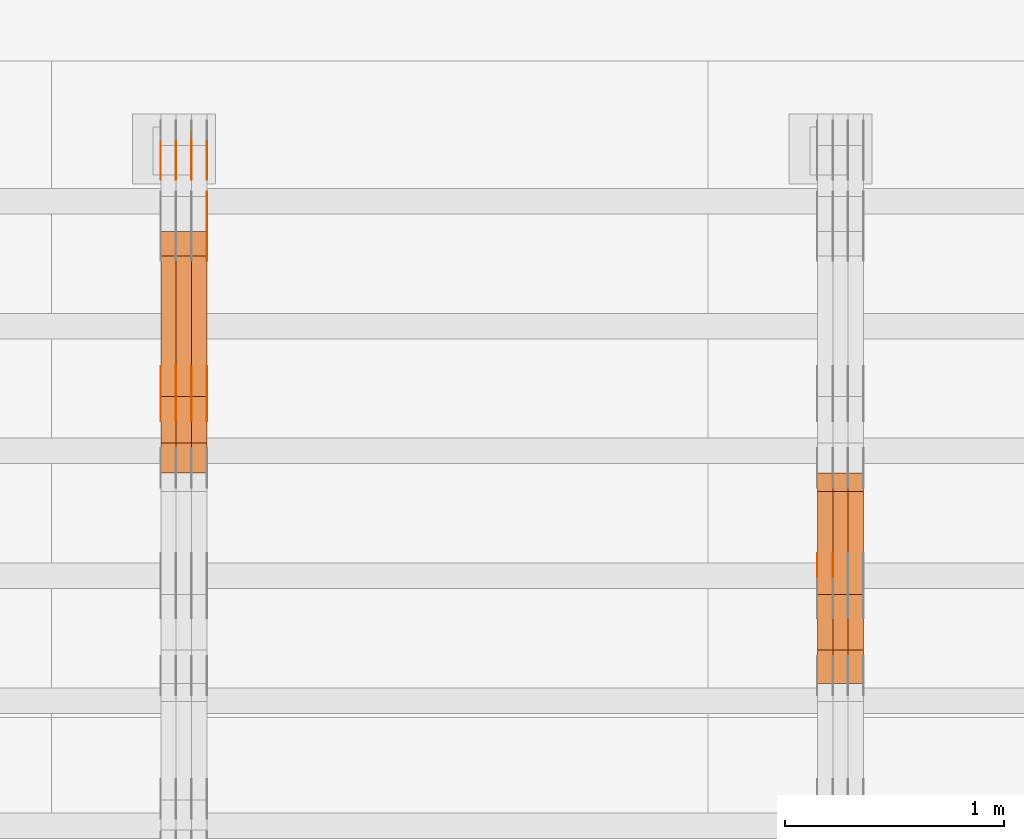
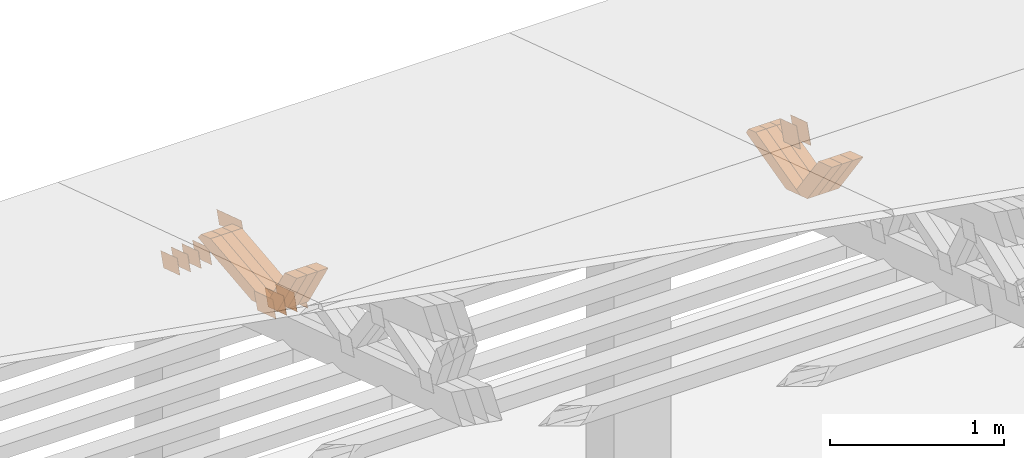
# One storey, part 348 of 385: 28 proxies.
"""IFC2X3 building model written with IfcOpenShell, lengths in millimetres."""

from ifc_helpers import new_model, entity, si_unit, converted_unit, derived_unit, direction, frame, origin, place, context, subcontext, project, spatial, polyline, outline, extrude, source, transform, mapped, material, type_object, type_shapes, element, save


model = new_model("IFC2X3")

# Units and contexts
model_context = context("Model", 3, precision=0.01, world=origin(), true_north=direction((6.12303176911189e-17, 1.0)))
body_context = subcontext(model_context, "Body", "Model", "MODEL_VIEW")
ifc_project = project(units=[si_unit("LENGTHUNIT", "METRE", prefix="MILLI"), si_unit("AREAUNIT", "SQUARE_METRE"), si_unit("VOLUMEUNIT", "CUBIC_METRE"), converted_unit("PLANEANGLEUNIT", "DEGREE", entity("IfcRatioMeasure", 0.0174532925199433), si_unit("PLANEANGLEUNIT", "RADIAN"), dimensions=[0, 0, 0, 0, 0, 0, 0]), si_unit("MASSUNIT", "GRAM", prefix="KILO"), derived_unit("MASSDENSITYUNIT", [(si_unit("MASSUNIT", "GRAM", prefix="KILO"), 1), (si_unit("LENGTHUNIT", "METRE"), -3)]), si_unit("TIMEUNIT", "SECOND"), si_unit("FREQUENCYUNIT", "HERTZ"), si_unit("THERMODYNAMICTEMPERATUREUNIT", "DEGREE_CELSIUS"), derived_unit("THERMALTRANSMITTANCEUNIT", [(si_unit("MASSUNIT", "GRAM", prefix="KILO"), 1), (si_unit("THERMODYNAMICTEMPERATUREUNIT", "KELVIN"), -1), (si_unit("TIMEUNIT", "SECOND"), -3)]), derived_unit("VOLUMETRICFLOWRATEUNIT", [(si_unit("LENGTHUNIT", "METRE"), 3), (si_unit("TIMEUNIT", "SECOND"), -1)]), si_unit("ELECTRICCURRENTUNIT", "AMPERE"), si_unit("ELECTRICVOLTAGEUNIT", "VOLT"), si_unit("POWERUNIT", "WATT"), si_unit("FORCEUNIT", "NEWTON", prefix="KILO"), si_unit("ILLUMINANCEUNIT", "LUX"), si_unit("LUMINOUSFLUXUNIT", "LUMEN"), si_unit("LUMINOUSINTENSITYUNIT", "CANDELA"), derived_unit("USERDEFINED", [(si_unit("MASSUNIT", "GRAM", prefix="KILO"), -1), (si_unit("LENGTHUNIT", "METRE"), -2), (si_unit("TIMEUNIT", "SECOND"), 3), (si_unit("LUMINOUSFLUXUNIT", "LUMEN"), 1)]), derived_unit("LINEARVELOCITYUNIT", [(si_unit("LENGTHUNIT", "METRE"), 1), (si_unit("TIMEUNIT", "SECOND"), -1)]), si_unit("PRESSUREUNIT", "PASCAL"), derived_unit("USERDEFINED", [(si_unit("LENGTHUNIT", "METRE"), -2), (si_unit("MASSUNIT", "GRAM", prefix="KILO"), 1), (si_unit("TIMEUNIT", "SECOND"), -2)])], contexts=[model_context])

# Site, building, storey
site_placement = place(None, origin())
site = spatial("IfcSite", under=ifc_project, at=site_placement, CompositionType="ELEMENT")
building_placement = place(site_placement, origin())
building = spatial("IfcBuilding", under=site, at=building_placement, CompositionType="ELEMENT")
storey_placement = place(building_placement, origin())
storey = spatial("IfcBuildingStorey", under=building, at=storey_placement, Name="Default", CompositionType="ELEMENT", Elevation=0.0)

# Proxies
ifc_material_1 = material(Name="IfcSurfaceStyle #467325")
building_element_proxy_type_1 = type_object("IfcBuildingElementProxyType", PredefinedType="NOTDEFINED", material=ifc_material_1)
shared_shape_1 = source(origin(), body_context, "Body", "SweptSolid", [
    extrude(outline(polyline([(-100.000009625089, -72.0000630699202), (100.000090167682, -72.0000630699202), (100.000009625089, 72.0000630699202), (-100.000090167682, 72.0000630699202), (-100.000009625089, -72.0000630699202)])), frame((100.000090167682, 72.0000630699202, 0.0), z_axis=(0.0, 0.0, 1.0), x_axis=(-1.0, 0.0, 0.0)), (0.0, 0.0, 1.0), 1.29999999999998),
])
type_shapes(building_element_proxy_type_1, [shared_shape_1])
proxy_1_placement = place(building_placement, frame((39245.0, 24447.7695802369, 1088.58717039832), z_axis=(-1.0, 0.0, 0.0), x_axis=(0.0, -0.951056516295154, 0.309016994374948)))
element("IfcBuildingElementProxy", 1, at=proxy_1_placement, inside=storey, type_object=building_element_proxy_type_1, material=ifc_material_1, context=body_context, shape_type="MappedRepresentation", body=[
    mapped(shared_shape_1, transform((0.0, 0.0, 0.0), scale=1.0)),
])
ifc_material_2 = material(Name="IfcSurfaceStyle #467268")
building_element_proxy_type_2 = type_object("IfcBuildingElementProxyType", PredefinedType="NOTDEFINED", material=ifc_material_2)
shared_shape_2 = source(origin(), body_context, "Body", "SweptSolid", [
    extrude(outline(polyline([(-100.000009625089, -72.0000630699202), (100.000090167682, -72.0000630699202), (100.000009625089, 72.0000630699202), (-100.000090167682, 72.0000630699202), (-100.000009625089, -72.0000630699202)])), frame((100.000090167682, 72.0000630699202, 0.0), z_axis=(0.0, 0.0, 1.0), x_axis=(-1.0, 0.0, 0.0)), (0.0, 0.0, 1.0), 1.29999999999998),
])
type_shapes(building_element_proxy_type_2, [shared_shape_2])
proxy_2_placement = place(building_placement, frame((39246.3, 24447.7695802369, 1088.58717039832), z_axis=(-1.0, 0.0, 0.0), x_axis=(0.0, -0.951056516295154, 0.309016994374948)))
element("IfcBuildingElementProxy", 2, at=proxy_2_placement, inside=storey, type_object=building_element_proxy_type_2, material=ifc_material_2, context=body_context, shape_type="MappedRepresentation", body=[
    mapped(shared_shape_2, transform((0.0, 0.0, 0.0), scale=1.0)),
])
ifc_material_3 = material(Name="IfcSurfaceStyle #467211")
building_element_proxy_type_3 = type_object("IfcBuildingElementProxyType", PredefinedType="NOTDEFINED", material=ifc_material_3)
shared_shape_3 = source(origin(), body_context, "Body", "SweptSolid", [
    extrude(outline(polyline([(-100.000009625089, -72.0000630699202), (100.000090167682, -72.0000630699202), (100.000009625089, 72.0000630699202), (-100.000090167682, 72.0000630699202), (-100.000009625089, -72.0000630699202)])), frame((100.000090167682, 72.0000630699202, 0.0), z_axis=(0.0, 0.0, 1.0), x_axis=(-1.0, 0.0, 0.0)), (0.0, 0.0, 1.0), 1.29999999999999),
])
type_shapes(building_element_proxy_type_3, [shared_shape_3])
proxy_3_placement = place(building_placement, frame((39175.0, 24447.7695802369, 1088.58717039832), z_axis=(-1.0, 0.0, 0.0), x_axis=(0.0, -0.951056516295154, 0.309016994374948)))
element("IfcBuildingElementProxy", 3, at=proxy_3_placement, inside=storey, type_object=building_element_proxy_type_3, material=ifc_material_3, context=body_context, shape_type="MappedRepresentation", body=[
    mapped(shared_shape_3, transform((0.0, 0.0, 0.0), scale=1.0)),
])
ifc_material_4 = material(Name="IfcSurfaceStyle #458298")
building_element_proxy_type_4 = type_object("IfcBuildingElementProxyType", Name="T1-W24 458296", PredefinedType="NOTDEFINED", material=ifc_material_4)
shared_shape_4 = source(origin(), body_context, "Body", "SweptSolid", [
    extrude(outline(polyline([(-215.642157779899, -47.4998772343114), (220.829928576248, -47.4998772343114), (202.182343865616, 6.34871490324596e-05), (137.545638852774, 47.4998454907369), (-344.915753514738, 47.4998454907369), (-215.642157779899, -47.4998772343114)])), frame((220.830079609702, 47.500154567531, 0.0), z_axis=(0.0, 0.0, 1.0), x_axis=(-1.0, 0.0, 0.0)), (0.0, 0.0, 1.0), 70.0),
])
type_shapes(building_element_proxy_type_4, [shared_shape_4])
proxy_4_placement = place(building_placement, frame((39385.0, 24227.7045444998, 781.019082122604), z_axis=(-1.0, 0.0, 0.0), x_axis=(0.0, -0.583381854128324, 0.812198012970851)))
element("IfcBuildingElementProxy", 4, at=proxy_4_placement, inside=storey, type_object=building_element_proxy_type_4, material=ifc_material_4, Name="T1-W24", context=body_context, shape_type="MappedRepresentation", body=[
    mapped(shared_shape_4, transform((0.0, 0.0, 0.0), scale=1.0)),
])
ifc_material_5 = material(Name="IfcSurfaceStyle #458232")
building_element_proxy_type_5 = type_object("IfcBuildingElementProxyType", Name="T1-W24 458230", PredefinedType="NOTDEFINED", material=ifc_material_5)
shared_shape_5 = source(origin(), body_context, "Body", "SweptSolid", [
    extrude(outline(polyline([(-215.642157779899, -47.4998772343114), (220.829928576248, -47.4998772343114), (202.182343865616, 6.34871490324596e-05), (137.545638852774, 47.4998454907369), (-344.915753514738, 47.4998454907369), (-215.642157779899, -47.4998772343114)])), frame((220.830079609702, 47.500154567531, 0.0), z_axis=(0.0, 0.0, 1.0), x_axis=(-1.0, 0.0, 0.0)), (0.0, 0.0, 1.0), 70.0),
])
type_shapes(building_element_proxy_type_5, [shared_shape_5])
proxy_5_placement = place(building_placement, frame((39315.0, 24227.7045444998, 781.019082122604), z_axis=(-1.0, 0.0, 0.0), x_axis=(0.0, -0.583381854128324, 0.812198012970851)))
element("IfcBuildingElementProxy", 5, at=proxy_5_placement, inside=storey, type_object=building_element_proxy_type_5, material=ifc_material_5, Name="T1-W24", context=body_context, shape_type="MappedRepresentation", body=[
    mapped(shared_shape_5, transform((0.0, 0.0, 0.0), scale=1.0)),
])
ifc_material_6 = material(Name="IfcSurfaceStyle #458166")
building_element_proxy_type_6 = type_object("IfcBuildingElementProxyType", Name="T1-W24 458164", PredefinedType="NOTDEFINED", material=ifc_material_6)
shared_shape_6 = source(origin(), body_context, "Body", "SweptSolid", [
    extrude(outline(polyline([(-215.642157779899, -47.4998772343114), (220.829928576248, -47.4998772343114), (202.182343865616, 6.34871490324596e-05), (137.545638852774, 47.4998454907369), (-344.915753514738, 47.4998454907369), (-215.642157779899, -47.4998772343114)])), frame((220.830079609702, 47.500154567531, 0.0), z_axis=(0.0, 0.0, 1.0), x_axis=(-1.0, 0.0, 0.0)), (0.0, 0.0, 1.0), 70.0),
])
type_shapes(building_element_proxy_type_6, [shared_shape_6])
proxy_6_placement = place(building_placement, frame((39245.0, 24227.7045444998, 781.019082122604), z_axis=(-1.0, 0.0, 0.0), x_axis=(0.0, -0.583381854128324, 0.812198012970851)))
element("IfcBuildingElementProxy", 6, at=proxy_6_placement, inside=storey, type_object=building_element_proxy_type_6, material=ifc_material_6, Name="T1-W24", context=body_context, shape_type="MappedRepresentation", body=[
    mapped(shared_shape_6, transform((0.0, 0.0, 0.0), scale=1.0)),
])
ifc_material_7 = material(Name="IfcSurfaceStyle #457902")
building_element_proxy_type_7 = type_object("IfcBuildingElementProxyType", Name="T1-W13 457900", PredefinedType="NOTDEFINED", material=ifc_material_7)
shared_shape_7 = source(origin(), body_context, "Body", "SweptSolid", [
    extrude(outline(polyline([(-384.339592151497, -47.5000055308246), (150.996422207105, -47.5000055308247), (226.265349299398, -4.29484466835994e-05), (240.878612116891, 47.500027005048), (-233.800791471897, 47.500027005048), (-384.339592151497, -47.5000055308246)])), frame((240.878612116891, 47.500027005048, 0.0), z_axis=(0.0, 0.0, 1.0), x_axis=(-1.0, 0.0, 0.0)), (0.0, 0.0, 1.0), 70.0),
])
type_shapes(building_element_proxy_type_7, [shared_shape_7])
proxy_7_placement = place(building_placement, frame((39385.0, 24884.765625, 885.749145507813), z_axis=(-1.0, 0.0, 0.0), x_axis=(0.0, -0.969210894563555, -0.246232089418326)))
element("IfcBuildingElementProxy", 7, at=proxy_7_placement, inside=storey, type_object=building_element_proxy_type_7, material=ifc_material_7, Name="T1-W13", context=body_context, shape_type="MappedRepresentation", body=[
    mapped(shared_shape_7, transform((0.0, 0.0, 0.0), scale=1.0)),
])
ifc_material_8 = material(Name="IfcSurfaceStyle #457836")
building_element_proxy_type_8 = type_object("IfcBuildingElementProxyType", Name="T1-W13 457834", PredefinedType="NOTDEFINED", material=ifc_material_8)
shared_shape_8 = source(origin(), body_context, "Body", "SweptSolid", [
    extrude(outline(polyline([(-384.339592151497, -47.5000055308246), (150.996422207105, -47.5000055308247), (226.265349299398, -4.29484466835994e-05), (240.878612116891, 47.500027005048), (-233.800791471897, 47.500027005048), (-384.339592151497, -47.5000055308246)])), frame((240.878612116891, 47.500027005048, 0.0), z_axis=(0.0, 0.0, 1.0), x_axis=(-1.0, 0.0, 0.0)), (0.0, 0.0, 1.0), 70.0),
])
type_shapes(building_element_proxy_type_8, [shared_shape_8])
proxy_8_placement = place(building_placement, frame((39315.0, 24884.765625, 885.749145507813), z_axis=(-1.0, 0.0, 0.0), x_axis=(0.0, -0.969210894563555, -0.246232089418326)))
element("IfcBuildingElementProxy", 8, at=proxy_8_placement, inside=storey, type_object=building_element_proxy_type_8, material=ifc_material_8, Name="T1-W13", context=body_context, shape_type="MappedRepresentation", body=[
    mapped(shared_shape_8, transform((0.0, 0.0, 0.0), scale=1.0)),
])
ifc_material_9 = material(Name="IfcSurfaceStyle #457770")
building_element_proxy_type_9 = type_object("IfcBuildingElementProxyType", Name="T1-W13 457768", PredefinedType="NOTDEFINED", material=ifc_material_9)
shared_shape_9 = source(origin(), body_context, "Body", "SweptSolid", [
    extrude(outline(polyline([(-384.339592151497, -47.5000055308246), (150.996422207105, -47.5000055308247), (226.265349299398, -4.29484466835994e-05), (240.878612116891, 47.500027005048), (-233.800791471897, 47.500027005048), (-384.339592151497, -47.5000055308246)])), frame((240.878612116891, 47.500027005048, 0.0), z_axis=(0.0, 0.0, 1.0), x_axis=(-1.0, 0.0, 0.0)), (0.0, 0.0, 1.0), 70.0),
])
type_shapes(building_element_proxy_type_9, [shared_shape_9])
proxy_9_placement = place(building_placement, frame((39245.0, 24884.765625, 885.749145507813), z_axis=(-1.0, 0.0, 0.0), x_axis=(0.0, -0.969210894563555, -0.246232089418326)))
element("IfcBuildingElementProxy", 9, at=proxy_9_placement, inside=storey, type_object=building_element_proxy_type_9, material=ifc_material_9, Name="T1-W13", context=body_context, shape_type="MappedRepresentation", body=[
    mapped(shared_shape_9, transform((0.0, 0.0, 0.0), scale=1.0)),
])
ifc_material_10 = material(Name="IfcSurfaceStyle #447086")
building_element_proxy_type_10 = type_object("IfcBuildingElementProxyType", PredefinedType="NOTDEFINED", material=ifc_material_10)
shared_shape_10 = source(origin(), body_context, "Body", "SweptSolid", [
    extrude(outline(polyline([(-100.000024997547, -54.0000105875654), (100.000088940899, -54.0000105875654), (99.9999100805868, 54.0000105875654), (-99.9999740239394, 54.0000105875654), (-100.000024997547, -54.0000105875654)])), frame((100.000088940899, 54.0000474633838, 0.0), z_axis=(0.0, 0.0, 1.0), x_axis=(-1.0, 0.0, 0.0)), (0.0, 0.0, 1.0), 1.3),
])
type_shapes(building_element_proxy_type_10, [shared_shape_10])
proxy_10_placement = place(building_placement, frame((36386.3, 26390.6212638563, 73.3227520411355), z_axis=(-1.0, 0.0, 0.0), x_axis=(0.0, -0.951056516295124, 0.309016994375039)))
element("IfcBuildingElementProxy", 10, at=proxy_10_placement, inside=storey, type_object=building_element_proxy_type_10, material=ifc_material_10, context=body_context, shape_type="MappedRepresentation", body=[
    mapped(shared_shape_10, transform((0.0, 0.0, 0.0), scale=1.0)),
])
ifc_material_11 = material(Name="IfcSurfaceStyle #447029")
building_element_proxy_type_11 = type_object("IfcBuildingElementProxyType", PredefinedType="NOTDEFINED", material=ifc_material_11)
shared_shape_11 = source(origin(), body_context, "Body", "SweptSolid", [
    extrude(outline(polyline([(-100.000024997547, -54.0000105875654), (100.000088940899, -54.0000105875654), (99.9999100805868, 54.0000105875654), (-99.9999740239394, 54.0000105875654), (-100.000024997547, -54.0000105875654)])), frame((100.000088940899, 54.0000474633838, 0.0), z_axis=(0.0, 0.0, 1.0), x_axis=(-1.0, 0.0, 0.0)), (0.0, 0.0, 1.0), 1.3),
])
type_shapes(building_element_proxy_type_11, [shared_shape_11])
proxy_11_placement = place(building_placement, frame((36315.0, 26390.6212638563, 73.3227520411355), z_axis=(-1.0, 0.0, 0.0), x_axis=(0.0, -0.951056516295124, 0.309016994375039)))
element("IfcBuildingElementProxy", 11, at=proxy_11_placement, inside=storey, type_object=building_element_proxy_type_11, material=ifc_material_11, context=body_context, shape_type="MappedRepresentation", body=[
    mapped(shared_shape_11, transform((0.0, 0.0, 0.0), scale=1.0)),
])
ifc_material_12 = material(Name="IfcSurfaceStyle #446972")
building_element_proxy_type_12 = type_object("IfcBuildingElementProxyType", PredefinedType="NOTDEFINED", material=ifc_material_12)
shared_shape_12 = source(origin(), body_context, "Body", "SweptSolid", [
    extrude(outline(polyline([(-100.000024997547, -54.0000105875654), (100.000088940899, -54.0000105875654), (99.9999100805868, 54.0000105875654), (-99.9999740239394, 54.0000105875654), (-100.000024997547, -54.0000105875654)])), frame((100.000088940899, 54.0000474633838, 0.0), z_axis=(0.0, 0.0, 1.0), x_axis=(-1.0, 0.0, 0.0)), (0.0, 0.0, 1.0), 1.3),
])
type_shapes(building_element_proxy_type_12, [shared_shape_12])
proxy_12_placement = place(building_placement, frame((36316.3, 26390.6212638563, 73.3227520411355), z_axis=(-1.0, 0.0, 0.0), x_axis=(0.0, -0.951056516295124, 0.309016994375039)))
element("IfcBuildingElementProxy", 12, at=proxy_12_placement, inside=storey, type_object=building_element_proxy_type_12, material=ifc_material_12, context=body_context, shape_type="MappedRepresentation", body=[
    mapped(shared_shape_12, transform((0.0, 0.0, 0.0), scale=1.0)),
])
ifc_material_13 = material(Name="IfcSurfaceStyle #446915")
building_element_proxy_type_13 = type_object("IfcBuildingElementProxyType", PredefinedType="NOTDEFINED", material=ifc_material_13)
shared_shape_13 = source(origin(), body_context, "Body", "SweptSolid", [
    extrude(outline(polyline([(-100.000024997547, -54.0000105875654), (100.000088940899, -54.0000105875654), (99.9999100805868, 54.0000105875654), (-99.9999740239394, 54.0000105875654), (-100.000024997547, -54.0000105875654)])), frame((100.000088940899, 54.0000474633838, 0.0), z_axis=(0.0, 0.0, 1.0), x_axis=(-1.0, 0.0, 0.0)), (0.0, 0.0, 1.0), 1.29999999999998),
])
type_shapes(building_element_proxy_type_13, [shared_shape_13])
proxy_13_placement = place(building_placement, frame((36245.0, 26390.6212638563, 73.3227520411355), z_axis=(-1.0, 0.0, 0.0), x_axis=(0.0, -0.951056516295124, 0.309016994375039)))
element("IfcBuildingElementProxy", 13, at=proxy_13_placement, inside=storey, type_object=building_element_proxy_type_13, material=ifc_material_13, context=body_context, shape_type="MappedRepresentation", body=[
    mapped(shared_shape_13, transform((0.0, 0.0, 0.0), scale=1.0)),
])
ifc_material_14 = material(Name="IfcSurfaceStyle #446858")
building_element_proxy_type_14 = type_object("IfcBuildingElementProxyType", PredefinedType="NOTDEFINED", material=ifc_material_14)
shared_shape_14 = source(origin(), body_context, "Body", "SweptSolid", [
    extrude(outline(polyline([(-100.000024997547, -54.0000105875654), (100.000088940899, -54.0000105875654), (99.9999100805868, 54.0000105875654), (-99.9999740239394, 54.0000105875654), (-100.000024997547, -54.0000105875654)])), frame((100.000088940899, 54.0000474633838, 0.0), z_axis=(0.0, 0.0, 1.0), x_axis=(-1.0, 0.0, 0.0)), (0.0, 0.0, 1.0), 1.29999999999998),
])
type_shapes(building_element_proxy_type_14, [shared_shape_14])
proxy_14_placement = place(building_placement, frame((36246.3, 26390.6212638563, 73.3227520411355), z_axis=(-1.0, 0.0, 0.0), x_axis=(0.0, -0.951056516295124, 0.309016994375039)))
element("IfcBuildingElementProxy", 14, at=proxy_14_placement, inside=storey, type_object=building_element_proxy_type_14, material=ifc_material_14, context=body_context, shape_type="MappedRepresentation", body=[
    mapped(shared_shape_14, transform((0.0, 0.0, 0.0), scale=1.0)),
])
ifc_material_15 = material(Name="IfcSurfaceStyle #446801")
building_element_proxy_type_15 = type_object("IfcBuildingElementProxyType", PredefinedType="NOTDEFINED", material=ifc_material_15)
shared_shape_15 = source(origin(), body_context, "Body", "SweptSolid", [
    extrude(outline(polyline([(-100.000024997547, -54.0000105875654), (100.000088940899, -54.0000105875654), (99.9999100805868, 54.0000105875654), (-99.9999740239394, 54.0000105875654), (-100.000024997547, -54.0000105875654)])), frame((100.000088940899, 54.0000474633838, 0.0), z_axis=(0.0, 0.0, 1.0), x_axis=(-1.0, 0.0, 0.0)), (0.0, 0.0, 1.0), 1.29999999999999),
])
type_shapes(building_element_proxy_type_15, [shared_shape_15])
proxy_15_placement = place(building_placement, frame((36175.0, 26390.6212638563, 73.3227520411355), z_axis=(-1.0, 0.0, 0.0), x_axis=(0.0, -0.951056516295124, 0.309016994375039)))
element("IfcBuildingElementProxy", 15, at=proxy_15_placement, inside=storey, type_object=building_element_proxy_type_15, material=ifc_material_15, context=body_context, shape_type="MappedRepresentation", body=[
    mapped(shared_shape_15, transform((0.0, 0.0, 0.0), scale=1.0)),
])
ifc_material_16 = material(Name="IfcSurfaceStyle #435116")
building_element_proxy_type_16 = type_object("IfcBuildingElementProxyType", PredefinedType="NOTDEFINED", material=ifc_material_16)
shared_shape_16 = source(origin(), body_context, "Body", "SweptSolid", [
    extrude(outline(polyline([(-112.50003853564, -60.0000121429077), (112.50002982902, -60.0000121429077), (112.500043250865, 60.0000121429077), (-112.500034544245, 60.0000121429077), (-112.50003853564, -60.0000121429077)])), frame((112.500056021398, 60.0000121429077, 0.0), z_axis=(0.0, 0.0, 1.0), x_axis=(-1.0, 0.0, 0.0)), (0.0, 0.0, 1.0), 1.3),
])
type_shapes(building_element_proxy_type_16, [shared_shape_16])
proxy_16_placement = place(building_placement, frame((36386.3, 25310.2182710494, 430.675738123044), z_axis=(-1.0, 0.0, 0.0), x_axis=(0.0, -0.951056516295124, 0.309016994375039)))
element("IfcBuildingElementProxy", 16, at=proxy_16_placement, inside=storey, type_object=building_element_proxy_type_16, material=ifc_material_16, context=body_context, shape_type="MappedRepresentation", body=[
    mapped(shared_shape_16, transform((0.0, 0.0, 0.0), scale=1.0)),
])
ifc_material_17 = material(Name="IfcSurfaceStyle #435059")
building_element_proxy_type_17 = type_object("IfcBuildingElementProxyType", PredefinedType="NOTDEFINED", material=ifc_material_17)
shared_shape_17 = source(origin(), body_context, "Body", "SweptSolid", [
    extrude(outline(polyline([(-112.50003853564, -60.0000121429077), (112.50002982902, -60.0000121429077), (112.500043250865, 60.0000121429077), (-112.500034544245, 60.0000121429077), (-112.50003853564, -60.0000121429077)])), frame((112.500056021398, 60.0000121429077, 0.0), z_axis=(0.0, 0.0, 1.0), x_axis=(-1.0, 0.0, 0.0)), (0.0, 0.0, 1.0), 1.3),
])
type_shapes(building_element_proxy_type_17, [shared_shape_17])
proxy_17_placement = place(building_placement, frame((36315.0, 25310.2182710494, 430.675738123044), z_axis=(-1.0, 0.0, 0.0), x_axis=(0.0, -0.951056516295124, 0.309016994375039)))
element("IfcBuildingElementProxy", 17, at=proxy_17_placement, inside=storey, type_object=building_element_proxy_type_17, material=ifc_material_17, context=body_context, shape_type="MappedRepresentation", body=[
    mapped(shared_shape_17, transform((0.0, 0.0, 0.0), scale=1.0)),
])
ifc_material_18 = material(Name="IfcSurfaceStyle #435002")
building_element_proxy_type_18 = type_object("IfcBuildingElementProxyType", PredefinedType="NOTDEFINED", material=ifc_material_18)
shared_shape_18 = source(origin(), body_context, "Body", "SweptSolid", [
    extrude(outline(polyline([(-112.50003853564, -60.0000121429077), (112.50002982902, -60.0000121429077), (112.500043250865, 60.0000121429077), (-112.500034544245, 60.0000121429077), (-112.50003853564, -60.0000121429077)])), frame((112.500056021398, 60.0000121429077, 0.0), z_axis=(0.0, 0.0, 1.0), x_axis=(-1.0, 0.0, 0.0)), (0.0, 0.0, 1.0), 1.3),
])
type_shapes(building_element_proxy_type_18, [shared_shape_18])
proxy_18_placement = place(building_placement, frame((36316.3, 25310.2182710494, 430.675738123044), z_axis=(-1.0, 0.0, 0.0), x_axis=(0.0, -0.951056516295124, 0.309016994375039)))
element("IfcBuildingElementProxy", 18, at=proxy_18_placement, inside=storey, type_object=building_element_proxy_type_18, material=ifc_material_18, context=body_context, shape_type="MappedRepresentation", body=[
    mapped(shared_shape_18, transform((0.0, 0.0, 0.0), scale=1.0)),
])
ifc_material_19 = material(Name="IfcSurfaceStyle #434945")
building_element_proxy_type_19 = type_object("IfcBuildingElementProxyType", PredefinedType="NOTDEFINED", material=ifc_material_19)
shared_shape_19 = source(origin(), body_context, "Body", "SweptSolid", [
    extrude(outline(polyline([(-112.50003853564, -60.0000121429077), (112.50002982902, -60.0000121429077), (112.500043250865, 60.0000121429077), (-112.500034544245, 60.0000121429077), (-112.50003853564, -60.0000121429077)])), frame((112.500056021398, 60.0000121429077, 0.0), z_axis=(0.0, 0.0, 1.0), x_axis=(-1.0, 0.0, 0.0)), (0.0, 0.0, 1.0), 1.29999999999998),
])
type_shapes(building_element_proxy_type_19, [shared_shape_19])
proxy_19_placement = place(building_placement, frame((36245.0, 25310.2182710494, 430.675738123044), z_axis=(-1.0, 0.0, 0.0), x_axis=(0.0, -0.951056516295124, 0.309016994375039)))
element("IfcBuildingElementProxy", 19, at=proxy_19_placement, inside=storey, type_object=building_element_proxy_type_19, material=ifc_material_19, context=body_context, shape_type="MappedRepresentation", body=[
    mapped(shared_shape_19, transform((0.0, 0.0, 0.0), scale=1.0)),
])
ifc_material_20 = material(Name="IfcSurfaceStyle #434888")
building_element_proxy_type_20 = type_object("IfcBuildingElementProxyType", PredefinedType="NOTDEFINED", material=ifc_material_20)
shared_shape_20 = source(origin(), body_context, "Body", "SweptSolid", [
    extrude(outline(polyline([(-112.50003853564, -60.0000121429077), (112.50002982902, -60.0000121429077), (112.500043250865, 60.0000121429077), (-112.500034544245, 60.0000121429077), (-112.50003853564, -60.0000121429077)])), frame((112.500056021398, 60.0000121429077, 0.0), z_axis=(0.0, 0.0, 1.0), x_axis=(-1.0, 0.0, 0.0)), (0.0, 0.0, 1.0), 1.29999999999998),
])
type_shapes(building_element_proxy_type_20, [shared_shape_20])
proxy_20_placement = place(building_placement, frame((36246.3, 25310.2182710494, 430.675738123044), z_axis=(-1.0, 0.0, 0.0), x_axis=(0.0, -0.951056516295124, 0.309016994375039)))
element("IfcBuildingElementProxy", 20, at=proxy_20_placement, inside=storey, type_object=building_element_proxy_type_20, material=ifc_material_20, context=body_context, shape_type="MappedRepresentation", body=[
    mapped(shared_shape_20, transform((0.0, 0.0, 0.0), scale=1.0)),
])
ifc_material_21 = material(Name="IfcSurfaceStyle #434831")
building_element_proxy_type_21 = type_object("IfcBuildingElementProxyType", PredefinedType="NOTDEFINED", material=ifc_material_21)
shared_shape_21 = source(origin(), body_context, "Body", "SweptSolid", [
    extrude(outline(polyline([(-112.50003853564, -60.0000121429077), (112.50002982902, -60.0000121429077), (112.500043250865, 60.0000121429077), (-112.500034544245, 60.0000121429077), (-112.50003853564, -60.0000121429077)])), frame((112.500056021398, 60.0000121429077, 0.0), z_axis=(0.0, 0.0, 1.0), x_axis=(-1.0, 0.0, 0.0)), (0.0, 0.0, 1.0), 1.29999999999999),
])
type_shapes(building_element_proxy_type_21, [shared_shape_21])
proxy_21_placement = place(building_placement, frame((36175.0, 25310.2182710494, 430.675738123044), z_axis=(-1.0, 0.0, 0.0), x_axis=(0.0, -0.951056516295124, 0.309016994375039)))
element("IfcBuildingElementProxy", 21, at=proxy_21_placement, inside=storey, type_object=building_element_proxy_type_21, material=ifc_material_21, context=body_context, shape_type="MappedRepresentation", body=[
    mapped(shared_shape_21, transform((0.0, 0.0, 0.0), scale=1.0)),
])
ifc_material_22 = material(Name="IfcSurfaceStyle #434432")
building_element_proxy_type_22 = type_object("IfcBuildingElementProxyType", PredefinedType="NOTDEFINED", material=ifc_material_22)
shared_shape_22 = source(origin(), body_context, "Body", "SweptSolid", [
    extrude(outline(polyline([(-149.999901061401, -48.0000057587028), (150.000035297123, -48.0000057587028), (149.999910491851, 48.0000057587028), (-150.000044727574, 48.0000057587028), (-149.999901061401, -48.0000057587028)])), frame((150.000035297123, 48.0000632585775, 0.0), z_axis=(0.0, 0.0, 1.0), x_axis=(-1.0, 0.0, 0.0)), (0.0, 0.0, 1.0), 1.29999999999999),
])
type_shapes(building_element_proxy_type_22, [shared_shape_22])
proxy_22_placement = place(building_placement, frame((36386.3, 26115.0176968219, 469.58296924555), z_axis=(-1.0, 0.0, 0.0), x_axis=(0.0, -0.951056516295154, 0.309016994374948)))
element("IfcBuildingElementProxy", 22, at=proxy_22_placement, inside=storey, type_object=building_element_proxy_type_22, material=ifc_material_22, context=body_context, shape_type="MappedRepresentation", body=[
    mapped(shared_shape_22, transform((0.0, 0.0, 0.0), scale=1.0)),
])
ifc_material_23 = material(Name="IfcSurfaceStyle #423074")
building_element_proxy_type_23 = type_object("IfcBuildingElementProxyType", Name="T1-W31 423072", PredefinedType="NOTDEFINED", material=ifc_material_23)
shared_shape_23 = source(origin(), body_context, "Body", "SweptSolid", [
    extrude(outline(polyline([(-201.245318299844, -47.5000121670808), (204.413774229459, -47.5000121670808), (182.034306640891, 5.35692244583164e-05), (126.70380769348, 47.4999853824686), (-311.906570263987, 47.4999853824686), (-201.245318299844, -47.5000121670808)])), frame((204.413774229459, 47.5002684334588, 0.0), z_axis=(0.0, 0.0, 1.0), x_axis=(-1.0, 0.0, 0.0)), (0.0, 0.0, 1.0), 70.0),
])
type_shapes(building_element_proxy_type_23, [shared_shape_23])
proxy_23_placement = place(building_placement, frame((36385.0, 25127.5652647985, 487.27008059185), z_axis=(-1.0, 0.0, 0.0), x_axis=(0.0, -0.520333970303023, 0.853962855953755)))
element("IfcBuildingElementProxy", 23, at=proxy_23_placement, inside=storey, type_object=building_element_proxy_type_23, material=ifc_material_23, Name="T1-W31", context=body_context, shape_type="MappedRepresentation", body=[
    mapped(shared_shape_23, transform((0.0, 0.0, 0.0), scale=1.0)),
])
ifc_material_24 = material(Name="IfcSurfaceStyle #423008")
building_element_proxy_type_24 = type_object("IfcBuildingElementProxyType", Name="T1-W31 423006", PredefinedType="NOTDEFINED", material=ifc_material_24)
shared_shape_24 = source(origin(), body_context, "Body", "SweptSolid", [
    extrude(outline(polyline([(-201.245318299844, -47.5000121670808), (204.413774229459, -47.5000121670808), (182.034306640891, 5.35692244583164e-05), (126.70380769348, 47.4999853824686), (-311.906570263987, 47.4999853824686), (-201.245318299844, -47.5000121670808)])), frame((204.413774229459, 47.5002684334588, 0.0), z_axis=(0.0, 0.0, 1.0), x_axis=(-1.0, 0.0, 0.0)), (0.0, 0.0, 1.0), 70.0),
])
type_shapes(building_element_proxy_type_24, [shared_shape_24])
proxy_24_placement = place(building_placement, frame((36315.0, 25127.5652647985, 487.27008059185), z_axis=(-1.0, 0.0, 0.0), x_axis=(0.0, -0.520333970303023, 0.853962855953755)))
element("IfcBuildingElementProxy", 24, at=proxy_24_placement, inside=storey, type_object=building_element_proxy_type_24, material=ifc_material_24, Name="T1-W31", context=body_context, shape_type="MappedRepresentation", body=[
    mapped(shared_shape_24, transform((0.0, 0.0, 0.0), scale=1.0)),
])
ifc_material_25 = material(Name="IfcSurfaceStyle #422942")
building_element_proxy_type_25 = type_object("IfcBuildingElementProxyType", Name="T1-W31 422940", PredefinedType="NOTDEFINED", material=ifc_material_25)
shared_shape_25 = source(origin(), body_context, "Body", "SweptSolid", [
    extrude(outline(polyline([(-201.245318299844, -47.5000121670808), (204.413774229459, -47.5000121670808), (182.034306640891, 5.35692244583164e-05), (126.70380769348, 47.4999853824686), (-311.906570263987, 47.4999853824686), (-201.245318299844, -47.5000121670808)])), frame((204.413774229459, 47.5002684334588, 0.0), z_axis=(0.0, 0.0, 1.0), x_axis=(-1.0, 0.0, 0.0)), (0.0, 0.0, 1.0), 70.0),
])
type_shapes(building_element_proxy_type_25, [shared_shape_25])
proxy_25_placement = place(building_placement, frame((36245.0, 25127.5652647985, 487.27008059185), z_axis=(-1.0, 0.0, 0.0), x_axis=(0.0, -0.520333970303023, 0.853962855953755)))
element("IfcBuildingElementProxy", 25, at=proxy_25_placement, inside=storey, type_object=building_element_proxy_type_25, material=ifc_material_25, Name="T1-W31", context=body_context, shape_type="MappedRepresentation", body=[
    mapped(shared_shape_25, transform((0.0, 0.0, 0.0), scale=1.0)),
])
ifc_material_26 = material(Name="IfcSurfaceStyle #422678")
building_element_proxy_type_26 = type_object("IfcBuildingElementProxyType", Name="T1-W4 422676", PredefinedType="NOTDEFINED", material=ifc_material_26)
shared_shape_26 = source(origin(), body_context, "Body", "SweptSolid", [
    extrude(outline(polyline([(-510.077325435179, -47.4999981284922), (188.854793418912, -47.4999981284922), (294.906688207675, 1.67015383116809e-05), (324.289382923648, 47.499989777723), (-297.973539115057, 47.4999897777231), (-510.077325435179, -47.4999981284922)])), frame((324.289382923648, 47.5000278316275, 0.0), z_axis=(0.0, 0.0, 1.0), x_axis=(-1.0, 0.0, 0.0)), (0.0, 0.0, 1.0), 70.0),
])
type_shapes(building_element_proxy_type_26, [shared_shape_26])
proxy_26_placement = place(building_placement, frame((36385.0, 25996.2241251556, 525.69905884318), z_axis=(-1.0, 0.0, 0.0), x_axis=(0.0, -0.994287125203057, -0.106738524701444)))
element("IfcBuildingElementProxy", 26, at=proxy_26_placement, inside=storey, type_object=building_element_proxy_type_26, material=ifc_material_26, Name="T1-W4", context=body_context, shape_type="MappedRepresentation", body=[
    mapped(shared_shape_26, transform((0.0, 0.0, 0.0), scale=1.0)),
])
ifc_material_27 = material(Name="IfcSurfaceStyle #422612")
building_element_proxy_type_27 = type_object("IfcBuildingElementProxyType", Name="T1-W4 422610", PredefinedType="NOTDEFINED", material=ifc_material_27)
shared_shape_27 = source(origin(), body_context, "Body", "SweptSolid", [
    extrude(outline(polyline([(-510.077325435179, -47.4999981284922), (188.854793418912, -47.4999981284922), (294.906688207675, 1.67015383116809e-05), (324.289382923648, 47.499989777723), (-297.973539115057, 47.4999897777231), (-510.077325435179, -47.4999981284922)])), frame((324.289382923648, 47.5000278316275, 0.0), z_axis=(0.0, 0.0, 1.0), x_axis=(-1.0, 0.0, 0.0)), (0.0, 0.0, 1.0), 70.0),
])
type_shapes(building_element_proxy_type_27, [shared_shape_27])
proxy_27_placement = place(building_placement, frame((36315.0, 25996.2241251556, 525.69905884318), z_axis=(-1.0, 0.0, 0.0), x_axis=(0.0, -0.994287125203057, -0.106738524701444)))
element("IfcBuildingElementProxy", 27, at=proxy_27_placement, inside=storey, type_object=building_element_proxy_type_27, material=ifc_material_27, Name="T1-W4", context=body_context, shape_type="MappedRepresentation", body=[
    mapped(shared_shape_27, transform((0.0, 0.0, 0.0), scale=1.0)),
])
ifc_material_28 = material(Name="IfcSurfaceStyle #422546")
building_element_proxy_type_28 = type_object("IfcBuildingElementProxyType", Name="T1-W4 422544", PredefinedType="NOTDEFINED", material=ifc_material_28)
shared_shape_28 = source(origin(), body_context, "Body", "SweptSolid", [
    extrude(outline(polyline([(-510.077325435179, -47.4999981284922), (188.854793418912, -47.4999981284922), (294.906688207675, 1.67015383116809e-05), (324.289382923648, 47.499989777723), (-297.973539115057, 47.4999897777231), (-510.077325435179, -47.4999981284922)])), frame((324.289382923648, 47.5000278316275, 0.0), z_axis=(0.0, 0.0, 1.0), x_axis=(-1.0, 0.0, 0.0)), (0.0, 0.0, 1.0), 70.0),
])
type_shapes(building_element_proxy_type_28, [shared_shape_28])
proxy_28_placement = place(building_placement, frame((36245.0, 25996.2241251556, 525.69905884318), z_axis=(-1.0, 0.0, 0.0), x_axis=(0.0, -0.994287125203057, -0.106738524701444)))
element("IfcBuildingElementProxy", 28, at=proxy_28_placement, inside=storey, type_object=building_element_proxy_type_28, material=ifc_material_28, Name="T1-W4", context=body_context, shape_type="MappedRepresentation", body=[
    mapped(shared_shape_28, transform((0.0, 0.0, 0.0), scale=1.0)),
])

save(model, "model.ifc")
